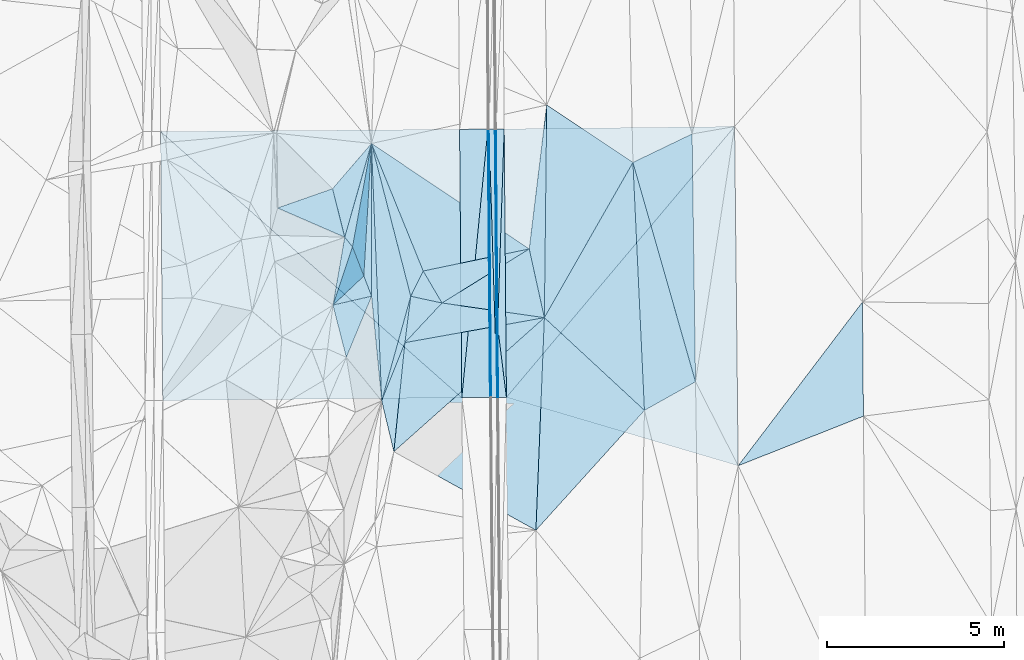
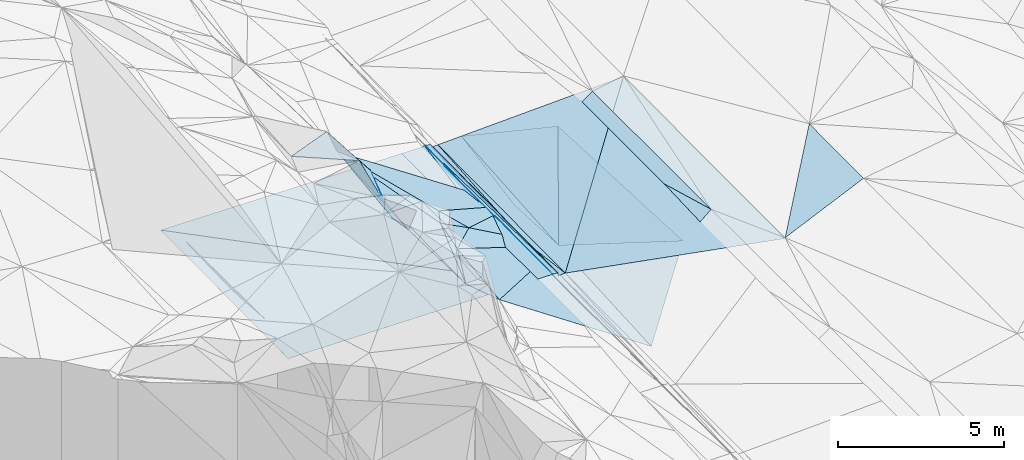
# One storey, part 22 of 275: 45 plates.
"""IFC2X3 building model written with IfcOpenShell, lengths in millimetres."""

from ifc_helpers import new_model, si_unit, frame, origin_with_axes, place, context, subcontext, project, spatial, polyline, outline, extrude, material, type_object, element, save


model = new_model("IFC2X3")

# Units and contexts
model_context = context("Model", 3, precision=1e-05, world=origin_with_axes())
body_context = subcontext(model_context, "Body", "Model", "MODEL_VIEW")
ifc_project = project(units=[si_unit("LENGTHUNIT", "METRE", prefix="MILLI"), si_unit("AREAUNIT", "SQUARE_METRE"), si_unit("VOLUMEUNIT", "CUBIC_METRE"), si_unit("MASSUNIT", "GRAM", prefix="KILO"), si_unit("TIMEUNIT", "SECOND"), si_unit("PLANEANGLEUNIT", "RADIAN"), si_unit("SOLIDANGLEUNIT", "STERADIAN"), si_unit("THERMODYNAMICTEMPERATUREUNIT", "DEGREE_CELSIUS"), si_unit("LUMINOUSINTENSITYUNIT", "LUMEN")], contexts=[model_context])

# Site, building, storey
site_placement = place(None, origin_with_axes())
site = spatial("IfcSite", under=ifc_project, at=site_placement, CompositionType="ELEMENT")
building_placement = place(site_placement, origin_with_axes())
building = spatial("IfcBuilding", under=site, at=building_placement, Name="Undefined", CompositionType="ELEMENT")
storey_placement = place(building_placement, origin_with_axes())
storey = spatial("IfcBuildingStorey", under=building, at=storey_placement, Name="Undefined", CompositionType="ELEMENT", Elevation=0.0)

# Plates
ifc_material = material()
plate_type_1 = type_object("IfcPlateType", PredefinedType="NOTDEFINED")
plate_1_placement = place(storey_placement, frame((-88318.7434168288, 29860.7642328056, 41740.5030603171), z_axis=(0.108922224468414, 0.0196809393756245, -0.993855426931979), x_axis=(-0.867843782507871, -0.485673655341589, -0.104729507158066)))
element("IfcPlate", 1, at=plate_1_placement, inside=storey, type_object=plate_type_1, material=ifc_material, Name="00", context=body_context, shape_type="SweptSolid", body=[
    extrude(outline(polyline([(0.0, 0.0), (1661.4228515625, -5.47152012586594e-09), (-1466.81262207031, 6270.64013671875), (0.0, 0.0)])), frame((-8.85201319254618e-08, 2.18876761149539e-07, -0.5000001331573), z_axis=(0.0, 0.0, 1.0), x_axis=(1.0, 0.0, 0.0)), (0.0, 0.0, 1.0), 1.0),
])
plate_type_2 = type_object("IfcPlateType", PredefinedType="NOTDEFINED")
plate_2_placement = place(storey_placement, frame((-93905.1665923007, 31421.8318345226, 41561.2393638872), z_axis=(0.0318706497103117, 0.0207933195969938, -0.999275687459262), x_axis=(0.03316870789238, 0.999210899184098, 0.0218498459595579)))
element("IfcPlate", 2, at=plate_2_placement, inside=storey, type_object=plate_type_2, material=ifc_material, Name="00_PR", context=body_context, shape_type="SweptSolid", body=[
    extrude(outline(polyline([(0.0, 0.0), (5580.31396484375, 9.25501808524132e-09), (-1992.28308105469, 314.197509765625), (0.0, 0.0)])), frame((-8.85201319254618e-08, 2.18876761149539e-07, -0.5000001331573), z_axis=(0.0, 0.0, 1.0), x_axis=(1.0, 0.0, 0.0)), (0.0, 0.0, 1.0), 1.0),
])
plate_type_3 = type_object("IfcPlateType", PredefinedType="NOTDEFINED")
plate_3_placement = place(storey_placement, frame((-93905.667598963, 31421.8196268005, 41561.6177487003), z_axis=(-0.97014307201474, -0.00362232545536715, -0.242506285650698), x_axis=(0.00887817011222381, -0.999748712835108, -0.0205837139506522)))
element("IfcPlate", 3, at=plate_3_placement, inside=storey, type_object=plate_type_3, material=ifc_material, Name="00_PR", context=body_context, shape_type="SweptSolid", body=[
    extrude(outline(polyline([(0.0, 0.0), (2003.62292480469, 3.33238858729601e-09), (2001.42541503906, 123.673454284668), (0.0, 0.0)])), frame((-8.85201319254618e-08, 2.18876761149539e-07, -0.5000001331573), z_axis=(0.0, 0.0, 1.0), x_axis=(1.0, 0.0, 0.0)), (0.0, 0.0, 1.0), 1.0),
])
plate_4_placement = place(storey_placement, frame((-93905.6676053102, 31421.8200178392, 41561.617763122), z_axis=(-0.970152990030112, -0.00283857405006044, -0.24247704722921), x_axis=(-0.0134247131204993, 0.999026690983602, 0.0420172319410268)))
element("IfcPlate", 4, at=plate_4_placement, inside=storey, type_object=plate_type_3, material=ifc_material, Name="00_PR", context=body_context, shape_type="SweptSolid", body=[
    extrude(outline(polyline([(0.0, 0.0), (5579.353515625, -9.27684595808387e-09), (5574.626953125, 123.602569580078), (0.0, 0.0)])), frame((-8.85201319254618e-08, 2.18876761149539e-07, -0.5000001331573), z_axis=(0.0, 0.0, 1.0), x_axis=(1.0, 0.0, 0.0)), (0.0, 0.0, 1.0), 1.0),
])
plate_type_4 = type_object("IfcPlateType", PredefinedType="NOTDEFINED")
plate_5_placement = place(storey_placement, frame((-94150.0887991111, 36994.4555994121, 41795.6682055449), z_axis=(-0.0201483089926879, 0.0203678080649482, -0.999589514770621), x_axis=(0.00431393510886213, -0.999781392457539, -0.0204586719886936)))
element("IfcPlate", 5, at=plate_5_placement, inside=storey, type_object=plate_type_4, material=ifc_material, Name="00_PR", context=body_context, shape_type="SweptSolid", body=[
    extrude(outline(polyline([(0.0, 0.0), (7579.7197265625, -7.65430741012096e-09), (0.0877222642302513, 30.0056610107422), (0.0, 0.0)])), frame((-8.85201319254618e-08, 2.18876761149539e-07, -0.5000001331573), z_axis=(0.0, 0.0, 1.0), x_axis=(1.0, 0.0, 0.0)), (0.0, 0.0, 1.0), 1.0),
])
plate_6_placement = place(storey_placement, frame((-94150.0887991111, 36994.4555994121, 41795.6682055449), z_axis=(-0.0201739026537976, 0.0203675858009815, -0.999589003090948), x_axis=(0.00827178911183922, -0.99975485381873, -0.0205380079554755)))
element("IfcPlate", 6, at=plate_6_placement, inside=storey, type_object=plate_type_4, material=ifc_material, Name="00_PR", context=body_context, shape_type="SweptSolid", body=[
    extrude(outline(polyline([(0.0, 0.0), (7579.654296875, 2.18278728425503e-08), (7579.66064453125, 30.0060653686523), (0.0, 0.0)])), frame((-8.85201319254618e-08, 2.18876761149539e-07, -0.5000001331573), z_axis=(0.0, 0.0, 1.0), x_axis=(1.0, 0.0, 0.0)), (0.0, 0.0, 1.0), 1.0),
])
plate_type_5 = type_object("IfcPlateType", PredefinedType="NOTDEFINED")
plate_7_placement = place(storey_placement, frame((-98177.3706167396, 30551.5065864134, 44729.7292345212), z_axis=(-0.782510472780183, -0.307343480532091, -0.541495470861719), x_axis=(-0.244082860591351, 0.95148945221725, -0.187326932086286)))
element("IfcPlate", 7, at=plate_7_placement, inside=storey, type_object=plate_type_5, material=ifc_material, Name="00", context=body_context, shape_type="SweptSolid", body=[
    extrude(outline(polyline([(0.0, 0.0), (1548.09558105469, -2.19733919948339e-09), (1844.45971679688, 2030.92797851563), (0.0, 0.0)])), frame((-8.85201319254618e-08, 2.18876761149539e-07, -0.5000001331573), z_axis=(0.0, 0.0, 1.0), x_axis=(1.0, 0.0, 0.0)), (0.0, 0.0, 1.0), 1.0),
])
plate_type_6 = type_object("IfcPlateType", PredefinedType="NOTDEFINED")
plate_8_placement = place(storey_placement, frame((-94917.3590876418, 29409.2702438355, 41656.5972050253), z_axis=(-0.0201739026537976, 0.0203675858009815, -0.999589003090948), x_axis=(0.0967295929284444, 0.995141994439362, 0.0183247579833139)))
element("IfcPlate", 8, at=plate_8_placement, inside=storey, type_object=plate_type_6, material=ifc_material, Name="00_PR", context=body_context, shape_type="SweptSolid", body=[
    extrude(outline(polyline([(0.0, 0.0), (7621.9833984375, -8.64383764564991e-09), (84.1752700805664, 795.720520019531), (0.0, 0.0)])), frame((-8.85201319254618e-08, 2.18876761149539e-07, -0.5000001331573), z_axis=(0.0, 0.0, 1.0), x_axis=(1.0, 0.0, 0.0)), (0.0, 0.0, 1.0), 1.0),
])
plate_type_7 = type_object("IfcPlateType", PredefinedType="NOTDEFINED")
plate_9_placement = place(storey_placement, frame((-93917.8745516895, 29418.1613766701, 41640.3803051223), z_axis=(-0.972377005305297, -0.00325050858887283, -0.233393217012442), x_axis=(-0.00827177011273422, 0.999754842040181, 0.0205385889587357)))
element("IfcPlate", 9, at=plate_9_placement, inside=storey, type_object=plate_type_7, material=ifc_material, Name="00_PR", context=body_context, shape_type="SweptSolid", body=[
    extrude(outline(polyline([(0.0, 0.0), (7579.43994140625, -1.29221007227898e-08), (2001.44873046875, 123.296836853027), (0.0, 0.0)])), frame((-8.85201319254618e-08, 2.18876761149539e-07, -0.5000001331573), z_axis=(0.0, 0.0, 1.0), x_axis=(1.0, 0.0, 0.0)), (0.0, 0.0, 1.0), 1.0),
])
plate_type_8 = type_object("IfcPlateType", PredefinedType="NOTDEFINED")
plate_10_placement = place(storey_placement, frame((-93657.3828465263, 29420.4880981374, 41527.4973733704), z_axis=(0.0324241072126785, 0.0208615178172464, -0.999256460747601), x_axis=(-0.999438984669865, -0.00771590211837413, -0.0325911149942626)))
element("IfcPlate", 10, at=plate_10_placement, inside=storey, type_object=plate_type_8, material=ifc_material, Name="00_PR", context=body_context, shape_type="SweptSolid", body=[
    extrude(outline(polyline([(0.0, 0.0), (230.124069213867, 3.71073838323355e-10), (231.102600097656, 2003.62268066406), (0.0, 0.0)])), frame((-8.85201319254618e-08, 2.18876761149539e-07, -0.5000001331573), z_axis=(0.0, 0.0, 1.0), x_axis=(1.0, 0.0, 0.0)), (0.0, 0.0, 1.0), 1.0),
])
plate_11_placement = place(storey_placement, frame((-93950.0771878318, 36996.4739117355, 41675.6683728359), z_axis=(0.0324695184545616, 0.0207730278541316, -0.999256829691496), x_axis=(0.999453590256385, 0.0055118561150687, 0.0325904950221537)))
element("IfcPlate", 11, at=plate_11_placement, inside=storey, type_object=plate_type_8, material=ifc_material, Name="00_PR", context=body_context, shape_type="SweptSolid", body=[
    extrude(outline(polyline([(0.0, 0.0), (230.128448486328, -7.42147676646709e-10), (10.4304323196411, 5575.9873046875), (0.0, 0.0)])), frame((-8.85201319254618e-08, 2.18876761149539e-07, -0.5000001331573), z_axis=(0.0, 0.0, 1.0), x_axis=(1.0, 0.0, 0.0)), (0.0, 0.0, 1.0), 1.0),
])
plate_type_9 = type_object("IfcPlateType", PredefinedType="NOTDEFINED")
plate_12_placement = place(storey_placement, frame((-92586.3096665834, 31670.9532829144, 40803.5528810715), z_axis=(-0.413602933278494, 0.17124300449581, -0.894208279426373), x_axis=(-0.907044964178533, -0.162455387672815, 0.388429761957602)))
element("IfcPlate", 12, at=plate_12_placement, inside=storey, type_object=plate_type_9, material=ifc_material, Name="00", context=body_context, shape_type="SweptSolid", body=[
    extrude(outline(polyline([(0.0, 0.0), (4340.55322265625, 2.70811142399907e-08), (3104.24047851563, 944.738830566406), (0.0, 0.0)])), frame((-8.85201319254618e-08, 2.18876761149539e-07, -0.5000001331573), z_axis=(0.0, 0.0, 1.0), x_axis=(1.0, 0.0, 0.0)), (0.0, 0.0, 1.0), 1.0),
])
plate_type_10 = type_object("IfcPlateType", PredefinedType="NOTDEFINED")
plate_13_placement = place(storey_placement, frame((-83604.0637909042, 32113.5014294466, 41879.5001985544), z_axis=(0.0196180793039476, 0.021856572786285, -0.999568617549822), x_axis=(0.00810992465610346, -0.999731612560153, -0.0217009670279464)))
element("IfcPlate", 13, at=plate_13_placement, inside=storey, type_object=plate_type_10, material=ifc_material, Name="00", context=body_context, shape_type="SweptSolid", body=[
    extrude(outline(polyline([(0.0, 0.0), (3225.66284179688, -7.8580342233181e-10), (4598.09375, 3548.08862304688), (0.0, 0.0)])), frame((-8.85201319254618e-08, 2.18876761149539e-07, -0.5000001331573), z_axis=(0.0, 0.0, 1.0), x_axis=(1.0, 0.0, 0.0)), (0.0, 0.0, 1.0), 1.0),
])
plate_type_11 = type_object("IfcPlateType", PredefinedType="NOTDEFINED")
plate_14_placement = place(storey_placement, frame((-103421.777179473, 36923.5816405609, 41981.1232056417), z_axis=(-0.0201499187135194, 0.0203650686364036, -0.999589538138167), x_axis=(0.999770813898466, 0.00764230011688339, -0.0199978730299795)))
element("IfcPlate", 14, at=plate_14_placement, inside=storey, type_object=plate_type_11, material=ifc_material, Name="00_PR", context=body_context, shape_type="SweptSolid", body=[
    extrude(outline(polyline([(0.0, 0.0), (8443.6484375, -4.91054379381239e-08), (8451.5322265625, 7580.6943359375), (0.0, 0.0)])), frame((-8.85201319254618e-08, 2.18876761149539e-07, -0.5000001331573), z_axis=(0.0, 0.0, 1.0), x_axis=(1.0, 0.0, 0.0)), (0.0, 0.0, 1.0), 1.0),
])
plate_type_12 = type_object("IfcPlateType", PredefinedType="NOTDEFINED")
plate_15_placement = place(storey_placement, frame((-94917.3590876418, 29409.2702438355, 41656.5972050253), z_axis=(-0.0201751323870035, 0.0203365349017685, -0.999589610480899), x_axis=(-0.999760405600465, -0.00890123511376445, 0.0199974850179736)))
element("IfcPlate", 15, at=plate_15_placement, inside=storey, type_object=plate_type_12, material=ifc_material, Name="00_PR", context=body_context, shape_type="SweptSolid", body=[
    extrude(outline(polyline([(0.0, 0.0), (8443.8115234375, 2.20716174226254e-08), (8441.9833984375, 7591.326171875), (0.0, 0.0)])), frame((-8.85201319254618e-08, 2.18876761149539e-07, -0.5000001331573), z_axis=(0.0, 0.0, 1.0), x_axis=(1.0, 0.0, 0.0)), (0.0, 0.0, 1.0), 1.0),
])
plate_type_13 = type_object("IfcPlateType", PredefinedType="NOTDEFINED")
plate_16_placement = place(storey_placement, frame((-94180.0877111954, 36994.2261371327, 41796.2682058085), z_axis=(-0.0201480650514236, 0.0203650848742638, -0.999589575172104), x_axis=(-0.0967295929361647, -0.995141994438609, -0.0183247579834524)))
element("IfcPlate", 16, at=plate_16_placement, inside=storey, type_object=plate_type_13, material=ifc_material, Name="00_PR", context=body_context, shape_type="SweptSolid", body=[
    extrude(outline(polyline([(0.0, 0.0), (7621.9833984375, -8.64383764564991e-09), (83.1740798950195, 795.825256347656), (0.0, 0.0)])), frame((-8.85201319254618e-08, 2.18876761149539e-07, -0.5000001331573), z_axis=(0.0, 0.0, 1.0), x_axis=(1.0, 0.0, 0.0)), (0.0, 0.0, 1.0), 1.0),
])
plate_type_14 = type_object("IfcPlateType", PredefinedType="NOTDEFINED")
plate_17_placement = place(storey_placement, frame((-93917.3884418482, 29418.1732700757, 41639.9971072728), z_axis=(-0.000156979242730399, 0.0205379933791506, -0.999789060845074), x_axis=(-0.0306920531079436, 0.999317961534645, 0.0205331349350507)))
element("IfcPlate", 17, at=plate_17_placement, inside=storey, type_object=plate_type_14, material=ifc_material, Name="00_PR", context=body_context, shape_type="SweptSolid", body=[
    extrude(outline(polyline([(0.0, 0.0), (7581.453125, 5.06406649947166e-09), (7577.5341796875, 169.95475769043), (0.0, 0.0)])), frame((-8.85201319254618e-08, 2.18876761149539e-07, -0.5000001331573), z_axis=(0.0, 0.0, 1.0), x_axis=(1.0, 0.0, 0.0)), (0.0, 0.0, 1.0), 1.0),
])
plate_18_placement = place(storey_placement, frame((-93917.3884418482, 29418.1732700757, 41639.9971072728), z_axis=(-0.00018289479036296, 0.0205371976049635, -0.999789072786871), x_axis=(-0.999960348043977, -0.00890518611643366, -2.87614657187699e-11)))
element("IfcPlate", 18, at=plate_18_placement, inside=storey, type_object=plate_type_14, material=ifc_material, Name="00_PR", context=body_context, shape_type="SweptSolid", body=[
    extrude(outline(polyline([(0.0, 0.0), (169.999771118164, -4.07453626394272e-10), (165.212936401367, 7579.65283203125), (0.0, 0.0)])), frame((-8.85201319254618e-08, 2.18876761149539e-07, -0.5000001331573), z_axis=(0.0, 0.0, 1.0), x_axis=(1.0, 0.0, 0.0)), (0.0, 0.0, 1.0), 1.0),
])
plate_type_15 = type_object("IfcPlateType", PredefinedType="NOTDEFINED")
plate_19_placement = place(storey_placement, frame((-87215.0661009943, 37066.3511049516, 41878.54933166), z_axis=(0.0297313165153319, 0.0208324414059416, -0.99934081183715), x_axis=(0.010544229097341, -0.999733696710425, -0.0205269309554676)))
element("IfcPlate", 19, at=plate_19_placement, inside=storey, type_object=plate_type_15, material=ifc_material, Name="00_PR", context=body_context, shape_type="SweptSolid", body=[
    extrude(outline(polyline([(0.0, 0.0), (9579.5126953125, -5.5733835324645e-09), (7583.103515625, 6525.52392578125), (0.0, 0.0)])), frame((-8.85201319254618e-08, 2.18876761149539e-07, -0.5000001331573), z_axis=(0.0, 0.0, 1.0), x_axis=(1.0, 0.0, 0.0)), (0.0, 0.0, 1.0), 1.0),
])
plate_type_16 = type_object("IfcPlateType", PredefinedType="NOTDEFINED")
plate_20_placement = place(storey_placement, frame((-93657.3841585022, 29420.4880540277, 41527.4973318834), z_axis=(0.0297965016160533, 0.0207774801915606, -0.999340014613812), x_axis=(-0.00827163710641466, 0.99975482491768, 0.0205394759767202)))
element("IfcPlate", 20, at=plate_20_placement, inside=storey, type_object=plate_type_16, material=ifc_material, Name="00_PR", context=body_context, shape_type="SweptSolid", body=[
    extrude(outline(polyline([(0.0, 0.0), (7579.1123046875, 7.91624188423157e-09), (7597.91015625, 6508.27783203125), (0.0, 0.0)])), frame((-8.85201319254618e-08, 2.18876761149539e-07, -0.5000001331573), z_axis=(0.0, 0.0, 1.0), x_axis=(1.0, 0.0, 0.0)), (0.0, 0.0, 1.0), 1.0),
])
plate_type_17 = type_object("IfcPlateType", PredefinedType="NOTDEFINED")
plate_21_placement = place(storey_placement, frame((-98002.7600289128, 33668.5668294645, 44259.8199143209), z_axis=(-0.895473582103993, 0.261560860203422, -0.360156882710146), x_axis=(0.193991338314388, -0.498913945261738, -0.844661018327684)))
element("IfcPlate", 21, at=plate_21_placement, inside=storey, type_object=plate_type_17, material=ifc_material, Name="00", context=body_context, shape_type="SweptSolid", body=[
    extrude(outline(polyline([(0.0, 0.0), (1645.63061523438, -5.3114490583539e-10), (560.879211425781, 1650.79211425781), (0.0, 0.0)])), frame((-8.85201319254618e-08, 2.18876761149539e-07, -0.5000001331573), z_axis=(0.0, 0.0, 1.0), x_axis=(1.0, 0.0, 0.0)), (0.0, 0.0, 1.0), 1.0),
])
plate_type_18 = type_object("IfcPlateType", PredefinedType="NOTDEFINED")
plate_22_placement = place(storey_placement, frame((-95476.3737093761, 32084.6358288654, 42219.5357686924), z_axis=(-0.367946473205596, 0.0512716145144804, -0.928432342392618), x_axis=(-0.908037069902287, 0.195174868308509, 0.370641943746287)))
element("IfcPlate", 22, at=plate_22_placement, inside=storey, type_object=plate_type_18, material=ifc_material, Name="00", context=body_context, shape_type="SweptSolid", body=[
    extrude(outline(polyline([(0.0, 0.0), (971.287780761719, -4.23460733145475e-09), (754.050415039063, 771.367553710938), (0.0, 0.0)])), frame((-8.85201319254618e-08, 2.18876761149539e-07, -0.5000001331573), z_axis=(0.0, 0.0, 1.0), x_axis=(1.0, 0.0, 0.0)), (0.0, 0.0, 1.0), 1.0),
])
plate_type_19 = type_object("IfcPlateType", PredefinedType="NOTDEFINED")
plate_23_placement = place(storey_placement, frame((-96358.3040894022, 32274.1877350578, 42579.522753702), z_axis=(-0.298042596681048, 0.0131453308552956, -0.954462053117002), x_axis=(-0.248167695737294, 0.964454479056837, 0.0907763880072748)))
element("IfcPlate", 23, at=plate_23_placement, inside=storey, type_object=plate_type_19, material=ifc_material, Name="00", context=body_context, shape_type="SweptSolid", body=[
    extrude(outline(polyline([(0.0, 0.0), (4472.52880859375, 7.82893039286137e-09), (591.394775390625, 540.788513183594), (0.0, 0.0)])), frame((-8.85201319254618e-08, 2.18876761149539e-07, -0.5000001331573), z_axis=(0.0, 0.0, 1.0), x_axis=(1.0, 0.0, 0.0)), (0.0, 0.0, 1.0), 1.0),
])
plate_type_20 = type_object("IfcPlateType", PredefinedType="NOTDEFINED")
plate_24_placement = place(storey_placement, frame((-97468.5011815685, 36587.6826762491, 42985.7166347212), z_axis=(-0.818111195852827, -0.097607295483226, -0.566715878627649), x_axis=(-0.165410260914569, -0.903899647032295, 0.394467836051391)))
element("IfcPlate", 24, at=plate_24_placement, inside=storey, type_object=plate_type_20, material=ifc_material, Name="00", context=body_context, shape_type="SweptSolid", body=[
    extrude(outline(polyline([(0.0, 0.0), (3229.66772460938, 1.28347892314196e-08), (3124.34106445313, 430.704437255859), (0.0, 0.0)])), frame((-8.85201319254618e-08, 2.18876761149539e-07, -0.5000001331573), z_axis=(0.0, 0.0, 1.0), x_axis=(1.0, 0.0, 0.0)), (0.0, 0.0, 1.0), 1.0),
])
plate_type_21 = type_object("IfcPlateType", PredefinedType="NOTDEFINED")
plate_25_placement = place(storey_placement, frame((-98222.133361137, 33943.1316098288, 44529.5155223338), z_axis=(-0.0592010926447179, 0.240100430955946, -0.968941181746571), x_axis=(-0.906236167320528, 0.394104705960234, 0.153027741864662)))
element("IfcPlate", 25, at=plate_25_placement, inside=storey, type_object=plate_type_21, material=ifc_material, Name="00", context=body_context, shape_type="SweptSolid", body=[
    extrude(outline(polyline([(0.0, 0.0), (2091.1240234375, -1.14996510092169e-08), (904.776550292969, 1140.47338867188), (0.0, 0.0)])), frame((-8.85201319254618e-08, 2.18876761149539e-07, -0.5000001331573), z_axis=(0.0, 0.0, 1.0), x_axis=(1.0, 0.0, 0.0)), (0.0, 0.0, 1.0), 1.0),
])
plate_type_22 = type_object("IfcPlateType", PredefinedType="NOTDEFINED")
plate_26_placement = place(storey_placement, frame((-98222.4462650269, 33943.0876796824, 44529.6437686939), z_axis=(-0.685011298611464, 0.15224003753078, -0.712448237942422), x_axis=(0.495700173140472, -0.619255743888449, -0.608936500802564)))
element("IfcPlate", 26, at=plate_26_placement, inside=storey, type_object=plate_type_22, material=ifc_material, Name="00", context=body_context, shape_type="SweptSolid", body=[
    extrude(outline(polyline([(0.0, 0.0), (443.39599609375, -1.45519152283669e-11), (1077.81762695313, 1623.94860839844), (0.0, 0.0)])), frame((-8.85201319254618e-08, 2.18876761149539e-07, -0.5000001331573), z_axis=(0.0, 0.0, 1.0), x_axis=(1.0, 0.0, 0.0)), (0.0, 0.0, 1.0), 1.0),
])
plate_type_23 = type_object("IfcPlateType", PredefinedType="NOTDEFINED")
plate_27_placement = place(storey_placement, frame((-97468.5740457469, 36587.7631932015, 42985.8705795726), z_axis=(-0.963839314012493, 0.0634255363174611, -0.258826154217012), x_axis=(-0.0573546798208185, -0.997874088923623, -0.0309474289320036)))
element("IfcPlate", 27, at=plate_27_placement, inside=storey, type_object=plate_type_23, material=ifc_material, Name="00", context=body_context, shape_type="SweptSolid", body=[
    extrude(outline(polyline([(0.0, 0.0), (3748.2919921875, -8.97853169590235e-09), (2904.30224609375, 1412.72119140625), (0.0, 0.0)])), frame((-8.85201319254618e-08, 2.18876761149539e-07, -0.5000001331573), z_axis=(0.0, 0.0, 1.0), x_axis=(1.0, 0.0, 0.0)), (0.0, 0.0, 1.0), 1.0),
])
plate_type_24 = type_object("IfcPlateType", PredefinedType="NOTDEFINED")
plate_28_placement = place(storey_placement, frame((-97683.4843485384, 32847.3220629087, 42869.7272217091), z_axis=(-0.820267974575434, -0.171883743078937, -0.54554232535257), x_axis=(0.348569874144508, -0.906426516837902, -0.238516272845253)))
element("IfcPlate", 28, at=plate_28_placement, inside=storey, type_object=plate_type_24, material=ifc_material, Name="00", context=body_context, shape_type="SweptSolid", body=[
    extrude(outline(polyline([(0.0, 0.0), (628.887878417969, -4.36557456851006e-11), (67.4206008911133, 1974.146484375), (0.0, 0.0)])), frame((-8.85201319254618e-08, 2.18876761149539e-07, -0.5000001331573), z_axis=(0.0, 0.0, 1.0), x_axis=(1.0, 0.0, 0.0)), (0.0, 0.0, 1.0), 1.0),
])
plate_type_25 = type_object("IfcPlateType", PredefinedType="NOTDEFINED")
plate_29_placement = place(storey_placement, frame((-97468.3242498415, 36587.7585307189, 42985.5579666063), z_axis=(-0.464246562100242, 0.0541008680865444, -0.884052162290432), x_axis=(0.000979327176106761, -0.998100774551438, -0.061594518896584)))
element("IfcPlate", 29, at=plate_29_placement, inside=storey, type_object=plate_type_25, material=ifc_material, Name="00", context=body_context, shape_type="SweptSolid", body=[
    extrude(outline(polyline([(0.0, 0.0), (4318.56591796875, 3.40514816343784e-09), (3740.154296875, 246.859634399414), (0.0, 0.0)])), frame((-8.85201319254618e-08, 2.18876761149539e-07, -0.5000001331573), z_axis=(0.0, 0.0, 1.0), x_axis=(1.0, 0.0, 0.0)), (0.0, 0.0, 1.0), 1.0),
])
plate_type_26 = type_object("IfcPlateType", PredefinedType="NOTDEFINED")
plate_30_placement = place(storey_placement, frame((-97468.2785413572, 36587.7598747055, 42985.536912719), z_axis=(-0.372831132856741, 0.0567890983002815, -0.926159783561671), x_axis=(0.0396864211817647, -0.996236138056295, -0.0770619569207912)))
element("IfcPlate", 30, at=plate_30_placement, inside=storey, type_object=plate_type_26, material=ifc_material, Name="00", context=body_context, shape_type="SweptSolid", body=[
    extrude(outline(polyline([(0.0, 0.0), (7292.83349609375, -2.62807589024305e-08), (4314.806640625, 180.15202331543), (0.0, 0.0)])), frame((-8.85201319254618e-08, 2.18876761149539e-07, -0.5000001331573), z_axis=(0.0, 0.0, 1.0), x_axis=(1.0, 0.0, 0.0)), (0.0, 0.0, 1.0), 1.0),
])
plate_type_27 = type_object("IfcPlateType", PredefinedType="NOTDEFINED")
plate_31_placement = place(storey_placement, frame((-96523.3574502452, 30965.7757746441, 42489.5358278627), z_axis=(-0.355555178627443, 0.108695405857547, -0.928313429665148), x_axis=(0.124839648364206, 0.989838170491026, 0.0680842010695565)))
element("IfcPlate", 31, at=plate_31_placement, inside=storey, type_object=plate_type_27, material=ifc_material, Name="00", context=body_context, shape_type="SweptSolid", body=[
    extrude(outline(polyline([(0.0, 0.0), (1321.892578125, 9.74978320300579e-10), (1219.84191894531, 965.911804199219), (0.0, 0.0)])), frame((-8.85201319254618e-08, 2.18876761149539e-07, -0.5000001331573), z_axis=(0.0, 0.0, 1.0), x_axis=(1.0, 0.0, 0.0)), (0.0, 0.0, 1.0), 1.0),
])
plate_type_28 = type_object("IfcPlateType", PredefinedType="NOTDEFINED")
plate_32_placement = place(storey_placement, frame((-96834.7259843366, 27886.7547315666, 42589.5149881097), z_axis=(0.236728424427107, -0.0554668406230706, -0.969991279682222), x_axis=(-0.231456573534666, 0.966405688395357, -0.111749272949262)))
element("IfcPlate", 32, at=plate_32_placement, inside=storey, type_object=plate_type_28, material=ifc_material, Name="00", context=body_context, shape_type="SweptSolid", body=[
    extrude(outline(polyline([(0.0, 0.0), (1485.46826171875, -2.38651409745216e-09), (2914.54223632813, 1045.20031738281), (0.0, 0.0)])), frame((-8.85201319254618e-08, 2.18876761149539e-07, -0.5000001331573), z_axis=(0.0, 0.0, 1.0), x_axis=(1.0, 0.0, 0.0)), (0.0, 0.0, 1.0), 1.0),
])
plate_type_29 = type_object("IfcPlateType", PredefinedType="NOTDEFINED")
plate_33_placement = place(storey_placement, frame((-97178.7041048491, 29322.384385159, 42423.502823519), z_axis=(-0.0766681241994358, 0.0738593461415413, -0.994317251041781), x_axis=(-0.0396864215816269, 0.996236138033273, 0.0770619570124942)))
element("IfcPlate", 33, at=plate_33_placement, inside=storey, type_object=plate_type_29, material=ifc_material, Name="00", context=body_context, shape_type="SweptSolid", body=[
    extrude(outline(polyline([(0.0, 0.0), (7292.83349609375, -2.62807589024305e-08), (2920.18188476563, 939.911376953125), (0.0, 0.0)])), frame((-8.85201319254618e-08, 2.18876761149539e-07, -0.5000001331573), z_axis=(0.0, 0.0, 1.0), x_axis=(1.0, 0.0, 0.0)), (0.0, 0.0, 1.0), 1.0),
])
plate_type_30 = type_object("IfcPlateType", PredefinedType="NOTDEFINED")
plate_34_placement = place(storey_placement, frame((-92519.7898267913, 37673.4010184549, 41168.6013226399), z_axis=(-0.601025913738886, 0.0551536021498145, -0.797324232156678), x_axis=(-0.0110764832854225, -0.998095075646455, -0.0606921040031177)))
element("IfcPlate", 34, at=plate_34_placement, inside=storey, type_object=plate_type_30, material=ifc_material, Name="00", context=body_context, shape_type="SweptSolid", body=[
    extrude(outline(polyline([(0.0, 0.0), (6013.9619140625, 2.06346157938242e-08), (4054.65893554688, 561.349426269531), (0.0, 0.0)])), frame((-8.85201319254618e-08, 2.18876761149539e-07, -0.5000001331573), z_axis=(0.0, 0.0, 1.0), x_axis=(1.0, 0.0, 0.0)), (0.0, 0.0, 1.0), 1.0),
])
plate_type_31 = type_object("IfcPlateType", PredefinedType="NOTDEFINED")
plate_35_placement = place(storey_placement, frame((-97468.513786357, 36587.6960909327, 42985.7334627758), z_axis=(-0.843121362742289, -0.0708165962457079, -0.533039752160904), x_axis=(-0.239073644631425, -0.838558458193642, 0.489554393948772)))
element("IfcPlate", 35, at=plate_35_placement, inside=storey, type_object=plate_type_31, material=ifc_material, Name="00", context=body_context, shape_type="SweptSolid", body=[
    extrude(outline(polyline([(0.0, 0.0), (3153.888671875, -3.50701157003641e-09), (2264.580078125, 1152.57556152344), (0.0, 0.0)])), frame((-8.85201319254618e-08, 2.18876761149539e-07, -0.5000001331573), z_axis=(0.0, 0.0, 1.0), x_axis=(1.0, 0.0, 0.0)), (0.0, 0.0, 1.0), 1.0),
])
plate_type_32 = type_object("IfcPlateType", PredefinedType="NOTDEFINED")
plate_36_placement = place(storey_placement, frame((-92824.0838387911, 25667.9823593464, 40809.5160555522), z_axis=(0.251240598341269, -0.0109329550277834, -0.967862920169732), x_axis=(0.0396342054697651, 0.999213757054639, -0.000998733965184611)))
element("IfcPlate", 36, at=plate_36_placement, inside=storey, type_object=plate_type_32, material=ifc_material, Name="00", context=body_context, shape_type="SweptSolid", body=[
    extrude(outline(polyline([(0.0, 0.0), (6007.60302734375, 3.01224645227194e-09), (3503.86059570313, 3024.138671875), (0.0, 0.0)])), frame((-8.85201319254618e-08, 2.18876761149539e-07, -0.5000001331573), z_axis=(0.0, 0.0, 1.0), x_axis=(1.0, 0.0, 0.0)), (0.0, 0.0, 1.0), 1.0),
])
plate_type_33 = type_object("IfcPlateType", PredefinedType="NOTDEFINED")
plate_37_placement = place(storey_placement, frame((-90085.4721116694, 36053.1868523793, 41669.503486798), z_axis=(0.116142834284628, 0.021750892803179, -0.992994330651791), x_axis=(0.895153946814674, 0.430896731523951, 0.114137716220747)))
element("IfcPlate", 37, at=plate_37_placement, inside=storey, type_object=plate_type_33, material=ifc_material, Name="00", context=body_context, shape_type="SweptSolid", body=[
    extrude(outline(polyline([(0.0, 0.0), (1866.16662597656, -7.05767888575792e-09), (-1078.69299316406, 6348.92822265625), (0.0, 0.0)])), frame((-8.85201319254618e-08, 2.18876761149539e-07, -0.5000001331573), z_axis=(0.0, 0.0, 1.0), x_axis=(1.0, 0.0, 0.0)), (0.0, 0.0, 1.0), 1.0),
])
plate_type_34 = type_object("IfcPlateType", PredefinedType="NOTDEFINED")
plate_38_placement = place(storey_placement, frame((-93013.2162370833, 33610.9781841227, 41259.5508326191), z_axis=(-0.423230040681963, 0.118011733889175, -0.898303714413346), x_axis=(0.209457392661771, -0.951877386648402, -0.223734309945393)))
element("IfcPlate", 38, at=plate_38_placement, inside=storey, type_object=plate_type_34, material=ifc_material, Name="00", context=body_context, shape_type="SweptSolid", body=[
    extrude(outline(polyline([(0.0, 0.0), (2038.13171386719, -4.42378222942352e-09), (722.141723632813, 2965.9755859375), (0.0, 0.0)])), frame((-8.85201319254618e-08, 2.18876761149539e-07, -0.5000001331573), z_axis=(0.0, 0.0, 1.0), x_axis=(1.0, 0.0, 0.0)), (0.0, 0.0, 1.0), 1.0),
])
plate_type_35 = type_object("IfcPlateType", PredefinedType="NOTDEFINED")
plate_39_placement = place(storey_placement, frame((-96358.2070784818, 32274.2218126987, 42579.5043613278), z_axis=(-0.104021588921346, 0.0813004099223197, -0.991246564879163), x_axis=(-0.124839648362577, -0.989838170491101, -0.0680842010714611)))
element("IfcPlate", 39, at=plate_39_placement, inside=storey, type_object=plate_type_35, material=ifc_material, Name="00", context=body_context, shape_type="SweptSolid", body=[
    extrude(outline(polyline([(0.0, 0.0), (1321.892578125, 9.74978320300579e-10), (3034.89111328125, 447.584808349609), (0.0, 0.0)])), frame((-8.85201319254618e-08, 2.18876761149539e-07, -0.5000001331573), z_axis=(0.0, 0.0, 1.0), x_axis=(1.0, 0.0, 0.0)), (0.0, 0.0, 1.0), 1.0),
])
plate_type_36 = type_object("IfcPlateType", PredefinedType="NOTDEFINED")
plate_40_placement = place(storey_placement, frame((-96523.3772591196, 30965.7265109078, 42489.5407100251), z_axis=(-0.395177246538733, 0.0101684154239192, -0.918548609027215), x_axis=(0.90704496403293, 0.162455388634292, -0.388429761895484)))
element("IfcPlate", 40, at=plate_40_placement, inside=storey, type_object=plate_type_36, material=ifc_material, Name="00", context=body_context, shape_type="SweptSolid", body=[
    extrude(outline(polyline([(0.0, 0.0), (4340.55322265625, 2.70811142399907e-08), (-821.72705078125, 2985.2578125), (0.0, 0.0)])), frame((-8.85201319254618e-08, 2.18876761149539e-07, -0.5000001331573), z_axis=(0.0, 0.0, 1.0), x_axis=(1.0, 0.0, 0.0)), (0.0, 0.0, 1.0), 1.0),
])
plate_type_37 = type_object("IfcPlateType", PredefinedType="NOTDEFINED")
plate_41_placement = place(storey_placement, frame((-93013.1913842488, 33610.908526875, 41259.5362963367), z_axis=(-0.37352014314208, -0.02130180548248, -0.927377450529344), x_axis=(-0.909276991668231, -0.189433389567395, 0.370581088750868)))
element("IfcPlate", 41, at=plate_41_placement, inside=storey, type_object=plate_type_37, material=ifc_material, Name="00", context=body_context, shape_type="SweptSolid", body=[
    extrude(outline(polyline([(0.0, 0.0), (3292.126953125, -8.47649062052369e-09), (4126.6240234375, 3828.74243164063), (0.0, 0.0)])), frame((-8.85201319254618e-08, 2.18876761149539e-07, -0.5000001331573), z_axis=(0.0, 0.0, 1.0), x_axis=(1.0, 0.0, 0.0)), (0.0, 0.0, 1.0), 1.0),
])
plate_type_38 = type_object("IfcPlateType", PredefinedType="NOTDEFINED")
plate_42_placement = place(storey_placement, frame((-92585.9843115252, 31670.895827028, 40803.5150663533), z_axis=(0.237134822969797, 0.0563424315420183, -0.969841536614624), x_axis=(0.0110764834499498, 0.998095075644179, 0.0606921040105222)))
element("IfcPlate", 42, at=plate_42_placement, inside=storey, type_object=plate_type_38, material=ifc_material, Name="00", context=body_context, shape_type="SweptSolid", body=[
    extrude(outline(polyline([(0.0, 0.0), (6013.9619140625, 2.06346157938242e-08), (4454.21728515625, 2523.36962890625), (0.0, 0.0)])), frame((-8.85201319254618e-08, 2.18876761149539e-07, -0.5000001331573), z_axis=(0.0, 0.0, 1.0), x_axis=(1.0, 0.0, 0.0)), (0.0, 0.0, 1.0), 1.0),
])
plate_type_39 = type_object("IfcPlateType", PredefinedType="NOTDEFINED")
plate_43_placement = place(storey_placement, frame((-89760.5113596033, 29053.8587197246, 41566.5207809968), z_axis=(0.284090779902764, 0.027289840093699, -0.958408938502714), x_axis=(-0.719660859398045, 0.666573136667801, -0.194341197185044)))
element("IfcPlate", 43, at=plate_43_placement, inside=storey, type_object=plate_type_39, material=ifc_material, Name="00", context=body_context, shape_type="SweptSolid", body=[
    extrude(outline(polyline([(0.0, 0.0), (3926.08471679688, 6.8903318606317e-09), (4879.35009765625, 5029.78466796875), (0.0, 0.0)])), frame((-8.85201319254618e-08, 2.18876761149539e-07, -0.5000001331573), z_axis=(0.0, 0.0, 1.0), x_axis=(1.0, 0.0, 0.0)), (0.0, 0.0, 1.0), 1.0),
])
plate_type_40 = type_object("IfcPlateType", PredefinedType="NOTDEFINED")
plate_44_placement = place(storey_placement, frame((-95476.3818732512, 32084.6301700116, 42219.5388000181), z_axis=(-0.384240151917919, 0.039953295838838, -0.922368277753365), x_axis=(-0.491581312547228, 0.836810759783571, 0.241030216912294)))
element("IfcPlate", 44, at=plate_44_placement, inside=storey, type_object=plate_type_40, material=ifc_material, Name="00", context=body_context, shape_type="SweptSolid", body=[
    extrude(outline(polyline([(0.0, 0.0), (1078.70288085938, -5.49334799870849e-09), (-165.013000488281, 3048.15869140625), (0.0, 0.0)])), frame((-8.85201319254618e-08, 2.18876761149539e-07, -0.5000001331573), z_axis=(0.0, 0.0, 1.0), x_axis=(1.0, 0.0, 0.0)), (0.0, 0.0, 1.0), 1.0),
])
plate_type_41 = type_object("IfcPlateType", PredefinedType="NOTDEFINED")
plate_45_placement = place(storey_placement, frame((-92586.3022417068, 31670.8751096545, 40803.5415080466), z_axis=(-0.398719200223673, 0.0148988416363298, -0.916952029220117), x_axis=(-0.0396342054115682, -0.999213757056926, 0.000998733986931571)))
element("IfcPlate", 45, at=plate_45_placement, inside=storey, type_object=plate_type_41, material=ifc_material, Name="00", context=body_context, shape_type="SweptSolid", body=[
    extrude(outline(polyline([(0.0, 0.0), (6007.60302734375, 3.01224645227194e-09), (3951.28930664063, 4466.34228515625), (0.0, 0.0)])), frame((-8.85201319254618e-08, 2.18876761149539e-07, -0.5000001331573), z_axis=(0.0, 0.0, 1.0), x_axis=(1.0, 0.0, 0.0)), (0.0, 0.0, 1.0), 1.0),
])

save(model, "model.ifc")
